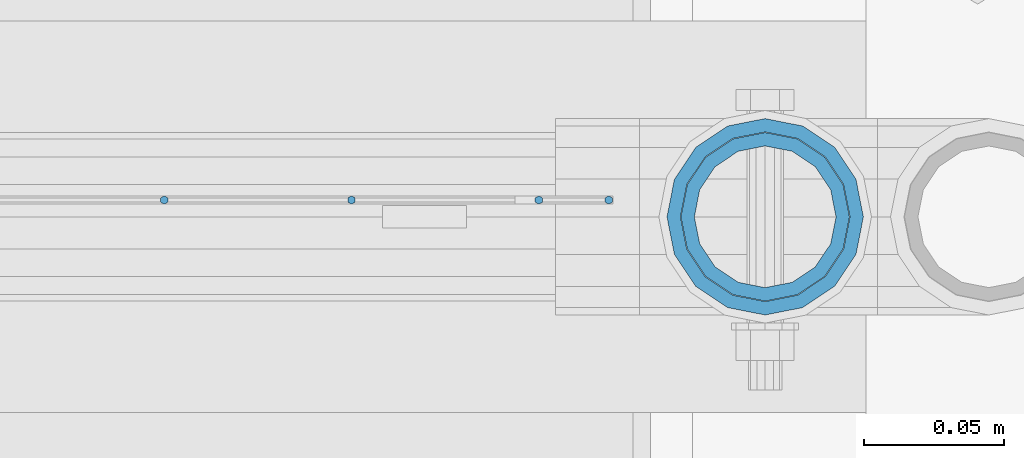
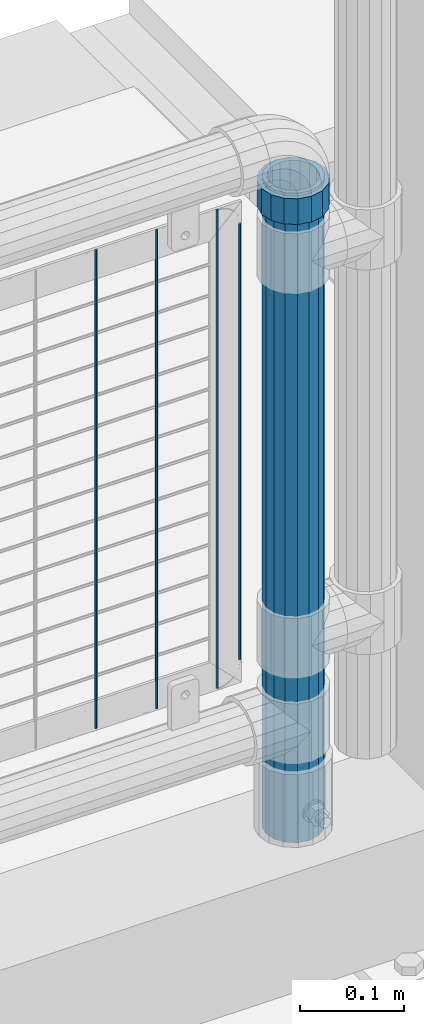
# One storey, part 105 of 247: 6 columns.
"""IFC2X3 building model written with IfcOpenShell, lengths in millimetres."""

from ifc_helpers import new_model, si_unit, frame, origin_with_axes, place, context, subcontext, project, spatial, faceted_brep, material, type_object, element, save


model = new_model("IFC2X3")

# Units and contexts
model_context = context("Model", 3, precision=1e-05, world=origin_with_axes())
body_context = subcontext(model_context, "Body", "Model", "MODEL_VIEW")
ifc_project = project(units=[si_unit("LENGTHUNIT", "METRE", prefix="MILLI"), si_unit("AREAUNIT", "SQUARE_METRE"), si_unit("VOLUMEUNIT", "CUBIC_METRE"), si_unit("MASSUNIT", "GRAM", prefix="KILO"), si_unit("TIMEUNIT", "SECOND"), si_unit("PLANEANGLEUNIT", "RADIAN"), si_unit("SOLIDANGLEUNIT", "STERADIAN"), si_unit("THERMODYNAMICTEMPERATUREUNIT", "DEGREE_CELSIUS"), si_unit("LUMINOUSINTENSITYUNIT", "LUMEN")], contexts=[model_context])

# Site, building, storey
site_placement = place(None, origin_with_axes())
site = spatial("IfcSite", under=ifc_project, at=site_placement, CompositionType="ELEMENT")
building_placement = place(site_placement, origin_with_axes())
building = spatial("IfcBuilding", under=site, at=building_placement, Name="Standard", CompositionType="ELEMENT")
storey_placement = place(building_placement, origin_with_axes())
storey = spatial("IfcBuildingStorey", under=building, at=storey_placement, Name="Undefined", CompositionType="ELEMENT", Elevation=0.0)

# Columns
ifc_material_1 = material(Name="Misc_Undefined")
column_type_1 = type_object("IfcColumnType", PredefinedType="NOTDEFINED")
column_1_placement = place(storey_placement, frame((16221.0, 7664.5, 894.85), z_axis=(1.0, 0.0, 0.0), x_axis=(0.0, 0.0, 1.0)))
element("IfcColumn", 1, at=column_1_placement, inside=storey, type_object=column_type_1, material=ifc_material_1, context=body_context, shape_type="Brep", body=[
    faceted_brep([(0.0, -30.3500000000004, 0.0), (0.0, -28.0397438117179, 11.6144421722802), (30.0, -28.0397438117179, 11.6144421722805), (30.0, -30.3500000000004, 0.0), (0.0, -21.4606908090118, 21.4606908090118), (30.0, -21.4606908090118, 21.4606908090117), (0.0, -11.6144421722802, 28.0397438117179), (30.0, -11.6144421722802, 28.0397438117175), (0.0, 0.0, 30.3500000000004), (30.0, 0.0, 30.35), (0.0, 11.6144421722802, 28.0397438117179), (30.0, 11.6144421722802, 28.0397438117175), (0.0, 21.4606908090118, 21.4606908090118), (30.0, 21.4606908090118, 21.4606908090117), (0.0, 28.0397438117179, 11.6144421722802), (30.0, 28.0397438117179, 11.6144421722805), (0.0, 30.3500000000004, 0.0), (30.0, 30.3500000000004, 0.0), (0.0, 28.0397438117179, -11.6144421722802), (30.0, 28.0397438117179, -11.6144421722805), (0.0, 21.4606908090118, -21.4606908090118), (30.0, 21.4606908090118, -21.4606908090117), (0.0, 11.6144421722802, -28.0397438117179), (30.0, 11.6144421722802, -28.0397438117175), (0.0, 0.0, -30.3500000000004), (30.0, 0.0, -30.35), (0.0, -11.6144421722802, -28.0397438117179), (30.0, -11.6144421722802, -28.0397438117175), (0.0, -21.4606908090118, -21.4606908090118), (30.0, -21.4606908090118, -21.4606908090117), (0.0, -28.0397438117179, -11.6144421722802), (30.0, -28.0397438117179, -11.6144421722805), (0.0, -35.1499999999996, 0.0), (0.0, -32.4743655677721, -13.4513226476338), (30.0, -32.4743655677721, -13.4513226476329), (30.0, -35.1499999999996, 0.0), (0.0, -24.8548033587067, -24.8548033587067), (30.0, -24.8548033587067, -24.8548033587072), (0.0, -13.4513226476329, -32.4743655677721), (30.0, -13.4513226476329, -32.4743655677717), (0.0, 0.0, -35.1499999999996), (30.0, 0.0, -35.15), (0.0, 13.4513226476329, -32.4743655677721), (30.0, 13.4513226476329, -32.4743655677717), (0.0, 24.8548033587067, -24.8548033587067), (30.0, 24.8548033587067, -24.8548033587072), (0.0, 32.4743655677721, -13.4513226476338), (30.0, 32.4743655677721, -13.4513226476329), (0.0, 35.1499999999996, 0.0), (30.0, 35.1499999999996, 0.0), (0.0, 32.4743655677721, 13.4513226476338), (30.0, 32.4743655677721, 13.4513226476329), (0.0, 24.8548033587067, 24.8548033587067), (30.0, 24.8548033587067, 24.8548033587072), (0.0, 13.4513226476329, 32.4743655677721), (30.0, 13.4513226476329, 32.4743655677717), (0.0, 0.0, 35.1499999999996), (30.0, 0.0, 35.15), (0.0, -13.4513226476329, 32.4743655677721), (30.0, -13.4513226476329, 32.4743655677717), (0.0, -24.8548033587067, 24.8548033587067), (30.0, -24.8548033587067, 24.8548033587072), (0.0, -32.4743655677721, 13.4513226476338), (30.0, -32.4743655677721, 13.4513226476329)], [[[0, 1, 2, 3]], [[1, 4, 5, 2]], [[4, 6, 7, 5]], [[6, 8, 9, 7]], [[8, 10, 11, 9]], [[10, 12, 13, 11]], [[12, 14, 15, 13]], [[14, 16, 17, 15]], [[16, 18, 19, 17]], [[18, 20, 21, 19]], [[20, 22, 23, 21]], [[22, 24, 25, 23]], [[24, 26, 27, 25]], [[26, 28, 29, 27]], [[28, 30, 31, 29]], [[30, 0, 3, 31]], [[32, 33, 34, 35]], [[33, 36, 37, 34]], [[36, 38, 39, 37]], [[38, 40, 41, 39]], [[40, 42, 43, 41]], [[42, 44, 45, 43]], [[44, 46, 47, 45]], [[46, 48, 49, 47]], [[48, 50, 51, 49]], [[50, 52, 53, 51]], [[52, 54, 55, 53]], [[54, 56, 57, 55]], [[56, 58, 59, 57]], [[58, 60, 61, 59]], [[60, 62, 63, 61]], [[62, 32, 35, 63]], [[37, 39, 41, 43, 45, 47, 49, 51, 53, 55, 57, 59, 61, 63, 35, 34], [5, 7, 9, 11, 13, 15, 17, 19, 21, 23, 25, 27, 29, 31, 3, 2]], [[62, 60, 58, 56, 54, 52, 50, 48, 46, 44, 42, 40, 38, 36, 33, 32], [30, 28, 26, 24, 22, 20, 18, 16, 14, 12, 10, 8, 6, 4, 1, 0]]]),
])
ifc_material_2 = material()
column_type_2 = type_object("IfcColumnType", PredefinedType="NOTDEFINED")
column_2_placement = place(storey_placement, frame((16221.0, 7664.5, 168.019999999998), z_axis=(-1.0, 0.0, 0.0), x_axis=(0.0, 0.0, 1.0)))
element("IfcColumn", 2, at=column_2_placement, inside=storey, type_object=column_type_2, material=ifc_material_2, context=body_context, shape_type="Brep", body=[
    faceted_brep([(0.0, -25.3500000000004, 0.0), (0.0, -23.4203461491616, 9.70102501045585), (760.0, -23.4203461491616, 9.70102501045585), (760.0, -25.3500000000004, 0.0), (0.0, -17.9251569030794, 17.9251569030785), (760.0, -17.9251569030794, 17.9251569030785), (0.0, -9.70102501045494, 23.4203461491616), (760.0, -9.70102501045494, 23.4203461491616), (0.0, 0.0, 25.3500000000004), (760.0, 0.0, 25.3500000000004), (0.0, 9.70102501045494, 23.4203461491616), (760.0, 9.70102501045494, 23.4203461491616), (0.0, 17.9251569030794, 17.9251569030785), (760.0, 17.9251569030794, 17.9251569030785), (0.0, 23.4203461491616, 9.70102501045585), (760.0, 23.4203461491616, 9.70102501045585), (0.0, 25.3500000000004, 0.0), (760.0, 25.3500000000004, 0.0), (0.0, 23.4203461491616, -9.70102501045585), (760.0, 23.4203461491616, -9.70102501045585), (0.0, 17.9251569030794, -17.9251569030785), (760.0, 17.9251569030794, -17.9251569030785), (0.0, 9.70102501045494, -23.4203461491616), (760.0, 9.70102501045494, -23.4203461491616), (0.0, 0.0, -25.3500000000004), (760.0, 0.0, -25.3500000000004), (0.0, -9.70102501045494, -23.4203461491616), (760.0, -9.70102501045494, -23.4203461491616), (0.0, -17.9251569030794, -17.9251569030785), (760.0, -17.9251569030794, -17.9251569030785), (0.0, -23.4203461491616, -9.70102501045585), (760.0, -23.4203461491616, -9.70102501045585), (0.0, -30.1499999999996, 0.0), (0.0, -27.8549679052148, -11.5379054858076), (760.0, -27.8549679052148, -11.5379054858076), (760.0, -30.1499999999996, 0.0), (0.0, -21.3192694527743, -21.3192694527752), (760.0, -21.3192694527743, -21.3192694527752), (0.0, -11.5379054858076, -27.8549679052157), (760.0, -11.5379054858076, -27.8549679052157), (0.0, 0.0, -30.1499999999996), (760.0, 0.0, -30.1499999999996), (0.0, 11.5379054858076, -27.8549679052157), (760.0, 11.5379054858076, -27.8549679052157), (0.0, 21.3192694527743, -21.3192694527752), (760.0, 21.3192694527743, -21.3192694527752), (0.0, 27.8549679052157, -11.5379054858076), (760.0, 27.8549679052157, -11.5379054858076), (0.0, 30.1499999999996, 0.0), (760.0, 30.1499999999996, 0.0), (0.0, 27.8549679052157, 11.5379054858076), (760.0, 27.8549679052157, 11.5379054858076), (0.0, 21.3192694527743, 21.3192694527752), (760.0, 21.3192694527743, 21.3192694527752), (0.0, 11.5379054858076, 27.8549679052157), (760.0, 11.5379054858076, 27.8549679052157), (0.0, 0.0, 30.1499999999996), (760.0, 0.0, 30.1499999999996), (0.0, -11.5379054858076, 27.8549679052157), (760.0, -11.5379054858076, 27.8549679052157), (0.0, -21.3192694527743, 21.3192694527752), (760.0, -21.3192694527743, 21.3192694527752), (0.0, -27.8549679052157, 11.5379054858076), (760.0, -27.8549679052157, 11.5379054858076)], [[[0, 1, 2, 3]], [[1, 4, 5, 2]], [[4, 6, 7, 5]], [[6, 8, 9, 7]], [[8, 10, 11, 9]], [[10, 12, 13, 11]], [[12, 14, 15, 13]], [[14, 16, 17, 15]], [[16, 18, 19, 17]], [[18, 20, 21, 19]], [[20, 22, 23, 21]], [[22, 24, 25, 23]], [[24, 26, 27, 25]], [[26, 28, 29, 27]], [[28, 30, 31, 29]], [[30, 0, 3, 31]], [[32, 33, 34, 35]], [[33, 36, 37, 34]], [[36, 38, 39, 37]], [[38, 40, 41, 39]], [[40, 42, 43, 41]], [[42, 44, 45, 43]], [[44, 46, 47, 45]], [[46, 48, 49, 47]], [[48, 50, 51, 49]], [[50, 52, 53, 51]], [[52, 54, 55, 53]], [[54, 56, 57, 55]], [[56, 58, 59, 57]], [[58, 60, 61, 59]], [[60, 62, 63, 61]], [[62, 32, 35, 63]], [[37, 39, 41, 43, 45, 47, 49, 51, 53, 55, 57, 59, 61, 63, 35, 34], [5, 7, 9, 11, 13, 15, 17, 19, 21, 23, 25, 27, 29, 31, 3, 2]], [[62, 60, 58, 56, 54, 52, 50, 48, 46, 44, 42, 40, 38, 36, 33, 32], [30, 28, 26, 24, 22, 20, 18, 16, 14, 12, 10, 8, 6, 4, 1, 0]]]),
])
column_type_3 = type_object("IfcColumnType", Name="D3", PredefinedType="NOTDEFINED")
for number, where, z_axis, x_axis in (
    (3, (16140.0020000001, 7670.49978410089, 353.02), (-1.0, 0.0, 0.0), (0.0, 0.0, 1.0)),
    (4, (16072.9740000001, 7670.49979830971, 353.02), (-1.0, 0.0, 0.0), (0.0, 0.0, 1.0)),
    (5, (16005.9460000001, 7670.49981251852, 353.02), (-1.0, 0.0, 0.0), (0.0, 0.0, 1.0)),
):
    element("IfcColumn", number, at=place(storey_placement, frame(where, z_axis=z_axis, x_axis=x_axis)), inside=storey, type_object=column_type_3, material=ifc_material_1, ObjectType="D3", context=body_context, shape_type="Brep", body=[
        faceted_brep([(1.81898940354586e-12, -1.5, -5.6843418860808e-14), (0.0, -0.75, -1.29903810567703), (560.0, -0.75, -1.29903810567703), (560.0, -1.5, 0.0), (0.0, 0.75, -1.29903810567703), (560.0, 0.75, -1.29903810567703), (1.81898940354586e-12, 1.5, -5.6843418860808e-14), (560.0, 1.5, 0.0), (0.0, 0.75, 1.29903810567703), (560.0, 0.75, 1.29903810567703), (0.0, -0.75, 1.29903810567703), (560.0, -0.75, 1.29903810567703)], [[[0, 1, 2, 3]], [[1, 4, 5, 2]], [[4, 6, 7, 5]], [[6, 8, 9, 7]], [[8, 10, 11, 9]], [[10, 0, 3, 11]], [[5, 7, 9, 11, 3, 2]], [[10, 8, 6, 4, 1, 0]]]),
    ])
column_3_placement = place(storey_placement, frame((16165.0000000001, 7670.49977880132, 378.02), z_axis=(-1.0, 0.0, 0.0), x_axis=(0.0, 0.0, 1.0)))
element("IfcColumn", 6, at=column_3_placement, inside=storey, type_object=column_type_3, material=ifc_material_1, ObjectType="D3", context=body_context, shape_type="Brep", body=[
    faceted_brep([(1.81898940354586e-12, -1.5, -5.6843418860808e-14), (0.0, -0.75, -1.29903810567703), (510.0, -0.75, -1.29903810567703), (510.0, -1.5, 0.0), (0.0, 0.75, -1.29903810567703), (510.0, 0.75, -1.29903810567703), (1.81898940354586e-12, 1.5, -5.6843418860808e-14), (510.0, 1.5, 0.0), (0.0, 0.75, 1.29903810567703), (510.0, 0.75, 1.29903810567703), (0.0, -0.75, 1.29903810567703), (510.0, -0.75, 1.29903810567703)], [[[0, 1, 2, 3]], [[1, 4, 5, 2]], [[4, 6, 7, 5]], [[6, 8, 9, 7]], [[8, 10, 11, 9]], [[10, 0, 3, 11]], [[5, 7, 9, 11, 3, 2]], [[10, 8, 6, 4, 1, 0]]]),
])

save(model, "model.ifc")
